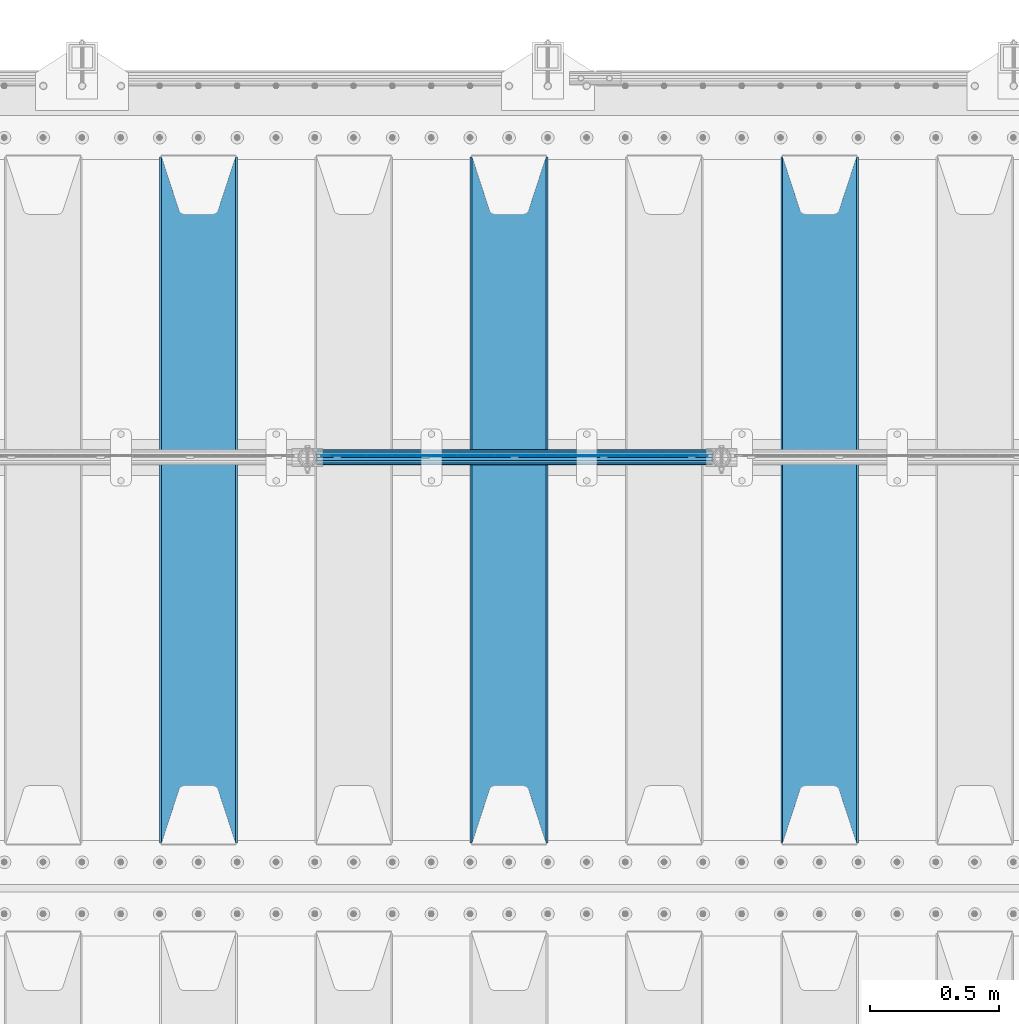
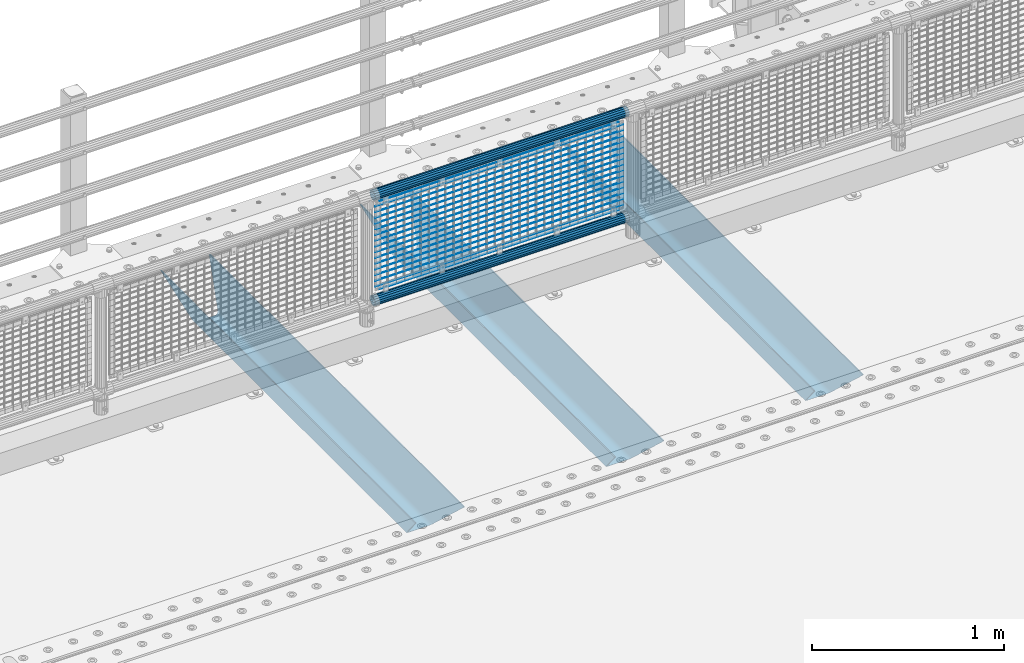
# One storey, part 123 of 257: 22 beams.
"""IFC2X3 building model written with IfcOpenShell, lengths in millimetres."""

import ifcopenshell
import ifcopenshell.guid

model = None  # the IFC model being written
_history = None  # IfcOwnerHistory: only IFC2X3 demands one
_inside = {}  # id of a spatial element -> (the spatial element, [elements in it])
_under = {}  # id of a project, library or spatial element -> (it, [spatial elements below it])
_declared = {}  # id of a project -> (the project, [libraries it declares])
_typed = {}  # id of a type object -> (the type object, [elements of that type])
_made_of = {}  # id of a material, layer set ... -> (it, [elements and type objects made of it])


def new_model(schema):
    """Start an empty IFC model of exactly this schema.

    Asked for "IFC4X3", IfcOpenShell would pick the latest addendum, in which some entities
    have other attributes; the version numbers below select the first issue.
    IFC2X3 requires an IfcOwnerHistory on every rooted entity: one is made here for all.
    """
    global model, _history
    if schema == "IFC4X3":
        model = ifcopenshell.file(schema_version=(4, 3, 0, 0))
    else:
        model = ifcopenshell.file(schema=schema)
    _inside.clear()
    _under.clear()
    _declared.clear()
    _typed.clear()
    _made_of.clear()
    _history = None
    if model.schema == "IFC2X3":
        org = make("IfcOrganization", Name="unknown")
        user = make(
            "IfcPersonAndOrganization",
            ThePerson=make("IfcPerson", FamilyName="unknown"),
            TheOrganization=org,
        )
        app = make(
            "IfcApplication",
            ApplicationDeveloper=org,
            Version="unknown",
            ApplicationFullName="unknown",
            ApplicationIdentifier="unknown",
        )
        _history = make(
            "IfcOwnerHistory",
            OwningUser=user,
            OwningApplication=app,
            ChangeAction="ADDED",
            CreationDate=0,
        )
    return model


def make(cls, **values):
    """One entity of the class cls with the attributes given. An attribute that is None is left unset."""
    return model.create_entity(
        cls, **{name: value for name, value in values.items() if value is not None}
    )


def rooted(cls, **values):
    """An entity with a GlobalId (a new one), such as an element, a storey or a relation."""
    return make(cls, GlobalId=ifcopenshell.guid.new(), OwnerHistory=_history, **values)


def si_unit(unit_type, name, prefix=None):
    """IfcSIUnit, for example si_unit("LENGTHUNIT", "METRE", prefix="MILLI")."""
    return make("IfcSIUnit", UnitType=unit_type, Prefix=prefix, Name=name)


def assignment(units):
    """IfcUnitAssignment: the units of a project."""
    return None if units is None else make("IfcUnitAssignment", Units=units)


def point(xyz):
    """IfcCartesianPoint."""
    return None if xyz is None else make("IfcCartesianPoint", Coordinates=xyz)


def direction(xyz):
    """IfcDirection."""
    return None if xyz is None else make("IfcDirection", DirectionRatios=xyz)


def frame(location, z_axis=None, x_axis=None):
    """IfcAxis2Placement3D, a coordinate frame: its origin and axes. An axis left out is left unset."""
    return make(
        "IfcAxis2Placement3D",
        Location=point(location),
        Axis=direction(z_axis),
        RefDirection=direction(x_axis),
    )


def origin_with_axes():
    """The frame at (0, 0, 0) with the z axis (0, 0, 1) and the x axis (1, 0, 0) written out."""
    return frame((0.0, 0.0, 0.0), z_axis=(0.0, 0.0, 1.0), x_axis=(1.0, 0.0, 0.0))


def place(relative_to, where):
    """IfcLocalPlacement: puts the frame where relative to a parent placement (None: the world)."""
    return make(
        "IfcLocalPlacement", PlacementRelTo=relative_to, RelativePlacement=where
    )


def context(
    kind, dimensions, precision=None, world=None, true_north=None, identifier=None
):
    """IfcGeometricRepresentationContext, for example the 3D "Model" context."""
    return make(
        "IfcGeometricRepresentationContext",
        ContextIdentifier=identifier,
        ContextType=kind,
        CoordinateSpaceDimension=dimensions,
        Precision=precision,
        WorldCoordinateSystem=world,
        TrueNorth=true_north,
    )


def subcontext(parent, identifier, kind, view, scale=None):
    """IfcGeometricRepresentationSubContext, for example "Body" below "Model"."""
    return make(
        "IfcGeometricRepresentationSubContext",
        ContextIdentifier=identifier,
        ContextType=kind,
        ParentContext=parent,
        TargetScale=scale,
        TargetView=view,
    )


def project(units=None, contexts=None):
    """IfcProject with its units and contexts."""
    return rooted(
        "IfcProject",
        Name="project",
        RepresentationContexts=contexts,
        UnitsInContext=assignment(units),
    )


def spatial(cls, under=None, at=None, **own):
    """A site, building, storey or space (cls), placed at a placement, below another one or the project."""
    s = rooted(cls, ObjectPlacement=at, **own)
    if under is not None:
        _under.setdefault(under.id(), (under, []))[1].append(s)
    return s


def faces_of(points, faces, orient=None, outer=None):
    """IfcFace entities. A face is a list of loops; a loop is a list of indices into points, from 0.

    orient and outer hold one flag for each loop. By default every Orientation is true, the
    first loop of a face is its IfcFaceOuterBound and the others are IfcFaceBound.
    """
    made = []
    for i, loops in enumerate(faces):
        bounds = []
        for j, loop in enumerate(loops):
            is_outer = j == 0 if outer is None else outer[i][j]
            bounds.append(
                make(
                    "IfcFaceOuterBound" if is_outer else "IfcFaceBound",
                    Bound=make("IfcPolyLoop", Polygon=[points[k] for k in loop]),
                    Orientation=True if orient is None else orient[i][j],
                )
            )
        made.append(make("IfcFace", Bounds=bounds))
    return made


def faceted_brep(points, faces, orient=None, outer=None, voids=None):
    """IfcFacetedBrep: a solid bounded by flat faces; with voids (closed shells), ...WithVoids."""
    shared = [point(p) for p in points]
    hull = make("IfcClosedShell", CfsFaces=faces_of(shared, faces, orient, outer))
    if voids is None:
        return make("IfcFacetedBrep", Outer=hull)
    return make(
        "IfcFacetedBrepWithVoids",
        Outer=hull,
        Voids=[
            make(cls, CfsFaces=faces_of(shared, fs, o, b)) for cls, fs, o, b in voids
        ],
    )


def shape(context_of_items, identifier, shape_type, items):
    """IfcShapeRepresentation: the items that make up one representation, for example the "Body"."""
    return make(
        "IfcShapeRepresentation",
        ContextOfItems=context_of_items,
        RepresentationIdentifier=identifier,
        RepresentationType=shape_type,
        Items=items,
    )


def material(Name=None, Category=None):
    """IfcMaterial."""
    return make("IfcMaterial", Name=Name, Category=Category)


def made_of(thing, what):
    """Note that an element or type object is made of a material, layer set ...; save() writes the relation."""
    if what is not None:
        _made_of.setdefault(what.id(), (what, []))[1].append(thing)
    return thing


def type_object(cls, material=None, **own):
    """A type object (cls), such as IfcWallType, which elements share."""
    return made_of(rooted(cls, **own), material)


def element(
    cls,
    number,
    at=None,
    inside=None,
    cuts=None,
    type_object=None,
    material=None,
    context=None,
    identifier="Body",
    shape_type=None,
    held_by="IfcProductDefinitionShape",
    body=None,
    shapes=None,
    **own,
):
    """One element of the class cls, such as IfcWall. Its Tag is "e" and its number.

    at: its placement. inside: the storey or other place that contains it. cuts: it is an
    opening in that element (IfcRelVoidsElement). A single representation is given by context,
    identifier, shape_type and body (its items); several are given by shapes. held_by: the class
    of the entity that holds the representations. save() writes the other relations.
    """
    e = rooted(cls, Tag="e%d" % number, ObjectPlacement=at, **own)
    if body is not None:
        shapes = [shape(context, identifier, shape_type, body)]
    if shapes is not None:
        e.Representation = make(held_by, Representations=shapes)
    if inside is not None:
        _inside.setdefault(inside.id(), (inside, []))[1].append(e)
    if cuts is not None:
        rooted(
            "IfcRelVoidsElement", RelatingBuildingElement=cuts, RelatedOpeningElement=e
        )
    if type_object is not None:
        _typed.setdefault(type_object.id(), (type_object, []))[1].append(e)
    return made_of(e, material)


def aggregate(whole, parts):
    """IfcRelAggregates: a whole, such as a stair, and the parts it consists of."""
    return rooted("IfcRelAggregates", RelatingObject=whole, RelatedObjects=parts)


def save(model, path):
    """Write the relations noted so far, then the file.

    IfcRelAggregates (storeys below a building ...), IfcRelContainedInSpatialStructure (elements
    in a storey), IfcRelDefinesByType, IfcRelAssociatesMaterial and IfcRelDeclares: one each for
    every whole, place, type object, material and project.
    """
    for whole, parts in _under.values():
        aggregate(whole, parts)
    for where, things in _inside.values():
        rooted(
            "IfcRelContainedInSpatialStructure",
            RelatedElements=things,
            RelatingStructure=where,
        )
    for kind, things in _typed.values():
        rooted("IfcRelDefinesByType", RelatedObjects=things, RelatingType=kind)
    for what, things in _made_of.values():
        rooted("IfcRelAssociatesMaterial", RelatedObjects=things, RelatingMaterial=what)
    for by, libraries in _declared.values():
        rooted("IfcRelDeclares", RelatingContext=by, RelatedDefinitions=libraries)
    model.write(path)


model = new_model("IFC2X3")

# Units and contexts
model_context = context("Model", 3, precision=1e-05, world=origin_with_axes())
body_context = subcontext(model_context, "Body", "Model", "MODEL_VIEW")
ifc_project = project(units=[si_unit("LENGTHUNIT", "METRE", prefix="MILLI"), si_unit("AREAUNIT", "SQUARE_METRE"), si_unit("VOLUMEUNIT", "CUBIC_METRE"), si_unit("MASSUNIT", "GRAM", prefix="KILO"), si_unit("TIMEUNIT", "SECOND"), si_unit("PLANEANGLEUNIT", "RADIAN"), si_unit("SOLIDANGLEUNIT", "STERADIAN"), si_unit("THERMODYNAMICTEMPERATUREUNIT", "DEGREE_CELSIUS"), si_unit("LUMINOUSINTENSITYUNIT", "LUMEN")], contexts=[model_context])

# Site, building, storey
site_placement = place(None, origin_with_axes())
site = spatial("IfcSite", under=ifc_project, at=site_placement, CompositionType="ELEMENT")
building_placement = place(site_placement, origin_with_axes())
building = spatial("IfcBuilding", under=site, at=building_placement, Name="Standard", CompositionType="ELEMENT")
storey_placement = place(building_placement, origin_with_axes())
storey = spatial("IfcBuildingStorey", under=building, at=storey_placement, Name="Undefined", CompositionType="ELEMENT", Elevation=0.0)

# Beams
ifc_material_1 = material(Name="STEEL/S355N")
beam_type_1 = type_object("IfcBeamType", PredefinedType="NOTDEFINED")
beam_1_placement = place(storey_placement, frame((53050.0, 9175.0, -115.0), z_axis=(0.0, 0.0, 1.0), x_axis=(0.0, 1.0, 0.0)))
element("IfcBeam", 1, at=beam_1_placement, inside=storey, type_object=beam_type_1, material=ifc_material_1, context=body_context, shape_type="Brep", body=[
    faceted_brep([(0.0, 150.0, 115.0), (0.0, 143.690000000002, 115.0), (2650.00000000297, 143.690000000002, 115.0), (2650.00000000297, 150.0, 115.0), (2650.00000000297, 142.059565218406, 110.0000000031), (2650.00000000297, 148.369565218403, 110.0000000031), (2441.90079219208, -80.1103600731149, -98.0992078077845), (2437.7588105432, -77.5672621345584, -102.241189456673), (2434.06523489746, -74.4080125315522, -105.934765102404), (2430.91086095089, -70.7102721255724, -109.089139048974), (2428.37322971128, -66.5649389910031, -111.626770288588), (2426.51472138055, -62.0739139532889, -113.485278619323), (2425.38102192091, -57.3475956567636, -114.618978078955), (2424.99999999987, -52.5021667386536, -115.0), (2424.99999999987, 52.5021667386536, -115.0), (2425.38102192091, 57.3475956567636, -114.618978078955), (2426.51472138055, 62.0739139532889, -113.485278619323), (2428.37322971128, 66.5649389910031, -111.626770288588), (2430.91086095089, 70.7102721255724, -109.089139048974), (2434.06523489746, 74.4080125315522, -105.934765102404), (2437.7588105432, 77.5672621345584, -102.241189456673), (2441.90079219208, 80.1103600731149, -98.0992078077846), (2446.38936140511, 81.9747917625791, -93.6106385947584), (2448.24948500409, 76.2713538057287, -91.7505149957729), (2444.62967112262, 74.76777986261, -95.3703288772456), (2441.28936334126, 72.7168944282894, -98.710636658607), (2438.31067330438, 70.1691124903809, -101.689326695487), (2435.76682334747, 67.1870637758839, -104.233176652398), (2433.72034654133, 63.8440531834931, -106.279653458539), (2432.22154950041, 60.2222587982324, -107.778450499454), (2431.30727574265, 56.4107117849126, -108.692724257221), (2430.99999999987, 52.5031078186876, -109.0), (2430.99999999987, -52.5031078186876, -109.0), (2431.30727574265, -56.4107117849126, -108.692724257221), (2432.22154950041, -60.2222587982324, -107.778450499454), (2433.72034654133, -63.8440531834931, -106.279653458539), (2435.76682334747, -67.1870637758839, -104.233176652398), (2438.31067330438, -70.1691124903809, -101.689326695487), (2441.28936334126, -72.7168944282894, -98.7106366586071), (2444.62967112262, -74.76777986261, -95.3703288772457), (2448.24948500409, -76.2713538057287, -91.7505149957729), (2650.00000000297, -142.059565218406, 110.0000000031), (2650.00000000297, -148.369565218403, 110.0000000031), (2446.38936140511, -81.9747917625791, -93.6106385947584), (2650.00000000297, -143.690000000002, 115.0), (2650.00000000297, -150.0, 115.0), (0.0, -143.690000000002, 115.0), (0.0, -150.0, 115.0), (0.0, -148.369565218258, 110.000000002662), (203.61063859742, -81.9747917625791, -93.6106385947584), (208.099207810447, -80.1103600731149, -98.0992078077845), (212.241189459335, -77.5672621345584, -102.241189456673), (215.934765105066, -74.4080125315522, -105.934765102404), (219.089139051636, -70.7102721255724, -109.089139048974), (221.626770291251, -66.5649389910031, -111.626770288588), (223.485278621985, -62.0739139532889, -113.485278619323), (224.618978081617, -57.3475956567636, -114.618978078955), (225.000000002662, -52.5021667386536, -115.0), (225.000000002662, 52.5021667386536, -115.0), (224.618978081617, 57.3475956567636, -114.618978078955), (223.485278621985, 62.0739139532889, -113.485278619323), (221.626770291251, 66.5649389910031, -111.626770288588), (219.089139051636, 70.7102721255724, -109.089139048974), (215.934765105066, 74.4080125315522, -105.934765102404), (212.241189459335, 77.5672621345584, -102.241189456673), (208.099207810447, 80.1103600731149, -98.0992078077846), (203.61063859742, 81.9747917625791, -93.6106385947584), (0.0, 148.369565218258, 110.000000002662), (0.0, 142.05956521826, 110.000000002662), (201.750514998435, 76.2713538057287, -91.7505149957729), (205.370328879908, 74.76777986261, -95.3703288772456), (208.710636661269, 72.7168944282894, -98.710636658607), (211.689326698149, 70.1691124903809, -101.689326695487), (214.233176655061, 67.1870637758839, -104.233176652398), (216.279653461201, 63.8440531834931, -106.279653458539), (217.778450502116, 60.2222587982324, -107.778450499454), (218.692724259884, 56.4107117849126, -108.692724257221), (219.000000002662, 52.5031078186876, -109.0), (219.000000002662, -52.5031078186876, -109.0), (218.692724259884, -56.4107117849126, -108.692724257221), (217.778450502116, -60.2222587982324, -107.778450499454), (216.279653461201, -63.8440531834931, -106.279653458539), (214.233176655061, -67.1870637758839, -104.233176652398), (211.689326698149, -70.1691124903809, -101.689326695487), (208.710636661269, -72.7168944282894, -98.7106366586071), (205.370328879908, -74.76777986261, -95.3703288772457), (201.750514998435, -76.2713538057287, -91.7505149957729), (0.0, -142.05956521826, 110.000000002662)], [[[0, 1, 2, 3]], [[3, 2, 4, 5]], [[6, 7, 8, 9, 10, 11, 12, 13, 14, 15, 16, 17, 18, 19, 20, 21, 22, 5, 4, 23, 24, 25, 26, 27, 28, 29, 30, 31, 32, 33, 34, 35, 36, 37, 38, 39, 40, 41, 42, 43]], [[44, 45, 42, 41]], [[46, 47, 45, 44]], [[43, 42, 45, 47, 48, 49]], [[6, 43, 49, 50]], [[7, 6, 50, 51]], [[8, 7, 51, 52]], [[9, 8, 52, 53]], [[10, 9, 53, 54]], [[11, 10, 54, 55]], [[12, 11, 55, 56]], [[13, 12, 56, 57]], [[14, 13, 57, 58]], [[15, 14, 58, 59]], [[16, 15, 59, 60]], [[17, 16, 60, 61]], [[18, 17, 61, 62]], [[19, 18, 62, 63]], [[20, 19, 63, 64]], [[21, 20, 64, 65]], [[22, 21, 65, 66]], [[0, 3, 5, 22, 66, 67]], [[1, 0, 67, 68]], [[23, 4, 2, 1, 68, 69]], [[24, 23, 69, 70]], [[25, 24, 70, 71]], [[26, 25, 71, 72]], [[27, 26, 72, 73]], [[28, 27, 73, 74]], [[29, 28, 74, 75]], [[30, 29, 75, 76]], [[31, 30, 76, 77]], [[32, 31, 77, 78]], [[33, 32, 78, 79]], [[34, 33, 79, 80]], [[35, 34, 80, 81]], [[36, 35, 81, 82]], [[37, 36, 82, 83]], [[38, 37, 83, 84]], [[39, 38, 84, 85]], [[40, 39, 85, 86]], [[46, 44, 41, 40, 86, 87]], [[47, 46, 87, 48]], [[86, 85, 84, 83, 82, 81, 80, 79, 78, 77, 76, 75, 74, 73, 72, 71, 70, 69, 68, 67, 66, 65, 64, 63, 62, 61, 60, 59, 58, 57, 56, 55, 54, 53, 52, 51, 50, 49, 48, 87]]]),
])
beam_2_placement = place(storey_placement, frame((51850.0, 9175.0, -115.0), z_axis=(0.0, 0.0, 1.0), x_axis=(0.0, 1.0, 0.0)))
element("IfcBeam", 2, at=beam_2_placement, inside=storey, type_object=beam_type_1, material=ifc_material_1, context=body_context, shape_type="Brep", body=[
    faceted_brep([(0.0, 150.0, 115.0), (0.0, 143.690000000002, 115.0), (2650.00000000297, 143.690000000002, 115.0), (2650.00000000297, 150.0, 115.0), (2650.00000000297, 142.059565218406, 110.0000000031), (2650.00000000297, 148.369565218403, 110.0000000031), (2441.90079219208, -80.1103600731149, -98.0992078077845), (2437.7588105432, -77.5672621345584, -102.241189456673), (2434.06523489746, -74.4080125315522, -105.934765102404), (2430.91086095089, -70.7102721255724, -109.089139048974), (2428.37322971128, -66.5649389910031, -111.626770288588), (2426.51472138055, -62.0739139532889, -113.485278619323), (2425.38102192091, -57.3475956567636, -114.618978078955), (2424.99999999987, -52.5021667386536, -115.0), (2424.99999999987, 52.5021667386536, -115.0), (2425.38102192091, 57.3475956567636, -114.618978078955), (2426.51472138055, 62.0739139532889, -113.485278619323), (2428.37322971128, 66.5649389910031, -111.626770288588), (2430.91086095089, 70.7102721255724, -109.089139048974), (2434.06523489746, 74.4080125315522, -105.934765102404), (2437.7588105432, 77.5672621345584, -102.241189456673), (2441.90079219208, 80.1103600731149, -98.0992078077846), (2446.38936140511, 81.9747917625791, -93.6106385947584), (2448.24948500409, 76.2713538057287, -91.7505149957729), (2444.62967112262, 74.76777986261, -95.3703288772456), (2441.28936334126, 72.7168944282894, -98.710636658607), (2438.31067330438, 70.1691124903809, -101.689326695487), (2435.76682334747, 67.1870637758839, -104.233176652398), (2433.72034654133, 63.8440531834931, -106.279653458539), (2432.22154950041, 60.2222587982324, -107.778450499454), (2431.30727574265, 56.4107117849126, -108.692724257221), (2430.99999999987, 52.5031078186876, -109.0), (2430.99999999987, -52.5031078186876, -109.0), (2431.30727574265, -56.4107117849126, -108.692724257221), (2432.22154950041, -60.2222587982324, -107.778450499454), (2433.72034654133, -63.8440531834931, -106.279653458539), (2435.76682334747, -67.1870637758839, -104.233176652398), (2438.31067330438, -70.1691124903809, -101.689326695487), (2441.28936334126, -72.7168944282894, -98.7106366586071), (2444.62967112262, -74.76777986261, -95.3703288772457), (2448.24948500409, -76.2713538057287, -91.7505149957729), (2650.00000000297, -142.059565218406, 110.0000000031), (2650.00000000297, -148.369565218403, 110.0000000031), (2446.38936140511, -81.9747917625791, -93.6106385947584), (2650.00000000297, -143.690000000002, 115.0), (2650.00000000297, -150.0, 115.0), (0.0, -143.690000000002, 115.0), (0.0, -150.0, 115.0), (0.0, -148.369565218258, 110.000000002662), (203.61063859742, -81.9747917625791, -93.6106385947584), (208.099207810447, -80.1103600731149, -98.0992078077845), (212.241189459335, -77.5672621345584, -102.241189456673), (215.934765105066, -74.4080125315522, -105.934765102404), (219.089139051636, -70.7102721255724, -109.089139048974), (221.626770291251, -66.5649389910031, -111.626770288588), (223.485278621985, -62.0739139532889, -113.485278619323), (224.618978081617, -57.3475956567636, -114.618978078955), (225.000000002662, -52.5021667386536, -115.0), (225.000000002662, 52.5021667386536, -115.0), (224.618978081617, 57.3475956567636, -114.618978078955), (223.485278621985, 62.0739139532889, -113.485278619323), (221.626770291251, 66.5649389910031, -111.626770288588), (219.089139051636, 70.7102721255724, -109.089139048974), (215.934765105066, 74.4080125315522, -105.934765102404), (212.241189459335, 77.5672621345584, -102.241189456673), (208.099207810447, 80.1103600731149, -98.0992078077846), (203.61063859742, 81.9747917625791, -93.6106385947584), (0.0, 148.369565218258, 110.000000002662), (0.0, 142.05956521826, 110.000000002662), (201.750514998435, 76.2713538057287, -91.7505149957729), (205.370328879908, 74.76777986261, -95.3703288772456), (208.710636661269, 72.7168944282894, -98.710636658607), (211.689326698149, 70.1691124903809, -101.689326695487), (214.233176655061, 67.1870637758839, -104.233176652398), (216.279653461201, 63.8440531834931, -106.279653458539), (217.778450502116, 60.2222587982324, -107.778450499454), (218.692724259884, 56.4107117849126, -108.692724257221), (219.000000002662, 52.5031078186876, -109.0), (219.000000002662, -52.5031078186876, -109.0), (218.692724259884, -56.4107117849126, -108.692724257221), (217.778450502116, -60.2222587982324, -107.778450499454), (216.279653461201, -63.8440531834931, -106.279653458539), (214.233176655061, -67.1870637758839, -104.233176652398), (211.689326698149, -70.1691124903809, -101.689326695487), (208.710636661269, -72.7168944282894, -98.7106366586071), (205.370328879908, -74.76777986261, -95.3703288772457), (201.750514998435, -76.2713538057287, -91.7505149957729), (0.0, -142.05956521826, 110.000000002662)], [[[0, 1, 2, 3]], [[3, 2, 4, 5]], [[6, 7, 8, 9, 10, 11, 12, 13, 14, 15, 16, 17, 18, 19, 20, 21, 22, 5, 4, 23, 24, 25, 26, 27, 28, 29, 30, 31, 32, 33, 34, 35, 36, 37, 38, 39, 40, 41, 42, 43]], [[44, 45, 42, 41]], [[46, 47, 45, 44]], [[43, 42, 45, 47, 48, 49]], [[6, 43, 49, 50]], [[7, 6, 50, 51]], [[8, 7, 51, 52]], [[9, 8, 52, 53]], [[10, 9, 53, 54]], [[11, 10, 54, 55]], [[12, 11, 55, 56]], [[13, 12, 56, 57]], [[14, 13, 57, 58]], [[15, 14, 58, 59]], [[16, 15, 59, 60]], [[17, 16, 60, 61]], [[18, 17, 61, 62]], [[19, 18, 62, 63]], [[20, 19, 63, 64]], [[21, 20, 64, 65]], [[22, 21, 65, 66]], [[0, 3, 5, 22, 66, 67]], [[1, 0, 67, 68]], [[23, 4, 2, 1, 68, 69]], [[24, 23, 69, 70]], [[25, 24, 70, 71]], [[26, 25, 71, 72]], [[27, 26, 72, 73]], [[28, 27, 73, 74]], [[29, 28, 74, 75]], [[30, 29, 75, 76]], [[31, 30, 76, 77]], [[32, 31, 77, 78]], [[33, 32, 78, 79]], [[34, 33, 79, 80]], [[35, 34, 80, 81]], [[36, 35, 81, 82]], [[37, 36, 82, 83]], [[38, 37, 83, 84]], [[39, 38, 84, 85]], [[40, 39, 85, 86]], [[46, 44, 41, 40, 86, 87]], [[47, 46, 87, 48]], [[86, 85, 84, 83, 82, 81, 80, 79, 78, 77, 76, 75, 74, 73, 72, 71, 70, 69, 68, 67, 66, 65, 64, 63, 62, 61, 60, 59, 58, 57, 56, 55, 54, 53, 52, 51, 50, 49, 48, 87]]]),
])
beam_3_placement = place(storey_placement, frame((50650.0, 9175.0, -115.0), z_axis=(0.0, 0.0, 1.0), x_axis=(0.0, 1.0, 0.0)))
element("IfcBeam", 3, at=beam_3_placement, inside=storey, type_object=beam_type_1, material=ifc_material_1, context=body_context, shape_type="Brep", body=[
    faceted_brep([(0.0, 150.0, 115.0), (0.0, 143.690000000002, 115.0), (2650.00000000297, 143.690000000002, 115.0), (2650.00000000297, 150.0, 115.0), (2650.00000000297, 142.059565218406, 110.0000000031), (2650.00000000297, 148.369565218403, 110.0000000031), (2441.90079219208, -80.1103600731149, -98.0992078077845), (2437.7588105432, -77.5672621345584, -102.241189456673), (2434.06523489746, -74.4080125315522, -105.934765102404), (2430.91086095089, -70.7102721255724, -109.089139048974), (2428.37322971128, -66.5649389910031, -111.626770288588), (2426.51472138055, -62.0739139532889, -113.485278619323), (2425.38102192091, -57.3475956567636, -114.618978078955), (2424.99999999987, -52.5021667386536, -115.0), (2424.99999999987, 52.5021667386536, -115.0), (2425.38102192091, 57.3475956567636, -114.618978078955), (2426.51472138055, 62.0739139532889, -113.485278619323), (2428.37322971128, 66.5649389910031, -111.626770288588), (2430.91086095089, 70.7102721255724, -109.089139048974), (2434.06523489746, 74.4080125315522, -105.934765102404), (2437.7588105432, 77.5672621345584, -102.241189456673), (2441.90079219208, 80.1103600731149, -98.0992078077846), (2446.38936140511, 81.9747917625791, -93.6106385947584), (2448.24948500409, 76.2713538057287, -91.7505149957729), (2444.62967112262, 74.76777986261, -95.3703288772456), (2441.28936334126, 72.7168944282894, -98.710636658607), (2438.31067330438, 70.1691124903809, -101.689326695487), (2435.76682334747, 67.1870637758839, -104.233176652398), (2433.72034654133, 63.8440531834931, -106.279653458539), (2432.22154950041, 60.2222587982324, -107.778450499454), (2431.30727574265, 56.4107117849126, -108.692724257221), (2430.99999999987, 52.5031078186876, -109.0), (2430.99999999987, -52.5031078186876, -109.0), (2431.30727574265, -56.4107117849126, -108.692724257221), (2432.22154950041, -60.2222587982324, -107.778450499454), (2433.72034654133, -63.8440531834931, -106.279653458539), (2435.76682334747, -67.1870637758839, -104.233176652398), (2438.31067330438, -70.1691124903809, -101.689326695487), (2441.28936334126, -72.7168944282894, -98.7106366586071), (2444.62967112262, -74.76777986261, -95.3703288772457), (2448.24948500409, -76.2713538057287, -91.7505149957729), (2650.00000000297, -142.059565218406, 110.0000000031), (2650.00000000297, -148.369565218403, 110.0000000031), (2446.38936140511, -81.9747917625791, -93.6106385947584), (2650.00000000297, -143.690000000002, 115.0), (2650.00000000297, -150.0, 115.0), (0.0, -143.690000000002, 115.0), (0.0, -150.0, 115.0), (0.0, -148.369565218258, 110.000000002662), (203.61063859742, -81.9747917625791, -93.6106385947584), (208.099207810447, -80.1103600731149, -98.0992078077845), (212.241189459335, -77.5672621345584, -102.241189456673), (215.934765105066, -74.4080125315522, -105.934765102404), (219.089139051636, -70.7102721255724, -109.089139048974), (221.626770291251, -66.5649389910031, -111.626770288588), (223.485278621985, -62.0739139532889, -113.485278619323), (224.618978081617, -57.3475956567636, -114.618978078955), (225.000000002662, -52.5021667386536, -115.0), (225.000000002662, 52.5021667386536, -115.0), (224.618978081617, 57.3475956567636, -114.618978078955), (223.485278621985, 62.0739139532889, -113.485278619323), (221.626770291251, 66.5649389910031, -111.626770288588), (219.089139051636, 70.7102721255724, -109.089139048974), (215.934765105066, 74.4080125315522, -105.934765102404), (212.241189459335, 77.5672621345584, -102.241189456673), (208.099207810447, 80.1103600731149, -98.0992078077846), (203.61063859742, 81.9747917625791, -93.6106385947584), (0.0, 148.369565218258, 110.000000002662), (0.0, 142.05956521826, 110.000000002662), (201.750514998435, 76.2713538057287, -91.7505149957729), (205.370328879908, 74.76777986261, -95.3703288772456), (208.710636661269, 72.7168944282894, -98.710636658607), (211.689326698149, 70.1691124903809, -101.689326695487), (214.233176655061, 67.1870637758839, -104.233176652398), (216.279653461201, 63.8440531834931, -106.279653458539), (217.778450502116, 60.2222587982324, -107.778450499454), (218.692724259884, 56.4107117849126, -108.692724257221), (219.000000002662, 52.5031078186876, -109.0), (219.000000002662, -52.5031078186876, -109.0), (218.692724259884, -56.4107117849126, -108.692724257221), (217.778450502116, -60.2222587982324, -107.778450499454), (216.279653461201, -63.8440531834931, -106.279653458539), (214.233176655061, -67.1870637758839, -104.233176652398), (211.689326698149, -70.1691124903809, -101.689326695487), (208.710636661269, -72.7168944282894, -98.7106366586071), (205.370328879908, -74.76777986261, -95.3703288772457), (201.750514998435, -76.2713538057287, -91.7505149957729), (0.0, -142.05956521826, 110.000000002662)], [[[0, 1, 2, 3]], [[3, 2, 4, 5]], [[6, 7, 8, 9, 10, 11, 12, 13, 14, 15, 16, 17, 18, 19, 20, 21, 22, 5, 4, 23, 24, 25, 26, 27, 28, 29, 30, 31, 32, 33, 34, 35, 36, 37, 38, 39, 40, 41, 42, 43]], [[44, 45, 42, 41]], [[46, 47, 45, 44]], [[43, 42, 45, 47, 48, 49]], [[6, 43, 49, 50]], [[7, 6, 50, 51]], [[8, 7, 51, 52]], [[9, 8, 52, 53]], [[10, 9, 53, 54]], [[11, 10, 54, 55]], [[12, 11, 55, 56]], [[13, 12, 56, 57]], [[14, 13, 57, 58]], [[15, 14, 58, 59]], [[16, 15, 59, 60]], [[17, 16, 60, 61]], [[18, 17, 61, 62]], [[19, 18, 62, 63]], [[20, 19, 63, 64]], [[21, 20, 64, 65]], [[22, 21, 65, 66]], [[0, 3, 5, 22, 66, 67]], [[1, 0, 67, 68]], [[23, 4, 2, 1, 68, 69]], [[24, 23, 69, 70]], [[25, 24, 70, 71]], [[26, 25, 71, 72]], [[27, 26, 72, 73]], [[28, 27, 73, 74]], [[29, 28, 74, 75]], [[30, 29, 75, 76]], [[31, 30, 76, 77]], [[32, 31, 77, 78]], [[33, 32, 78, 79]], [[34, 33, 79, 80]], [[35, 34, 80, 81]], [[36, 35, 81, 82]], [[37, 36, 82, 83]], [[38, 37, 83, 84]], [[39, 38, 84, 85]], [[40, 39, 85, 86]], [[46, 44, 41, 40, 86, 87]], [[47, 46, 87, 48]], [[86, 85, 84, 83, 82, 81, 80, 79, 78, 77, 76, 75, 74, 73, 72, 71, 70, 69, 68, 67, 66, 65, 64, 63, 62, 61, 60, 59, 58, 57, 56, 55, 54, 53, 52, 51, 50, 49, 48, 87]]]),
])
ifc_material_2 = material(Name="Misc_Undefined")
beam_type_2 = type_object("IfcBeamType", Name="D3", PredefinedType="NOTDEFINED")
for number, where, z_axis, x_axis in (
    (4, (51126.0, 10670.5, 851.597000000003), (0.0, 0.0, 1.0), (1.0, 0.0, 0.0)),
    (5, (51126.0, 10670.5, 669.452000000003), (0.0, 0.0, 1.0), (1.0, 0.0, 0.0)),
    (6, (51126.0, 10670.5, 523.736000000003), (0.0, 0.0, 1.0), (1.0, 0.0, 0.0)),
    (7, (51126.0, 10670.5, 487.307000000003), (0.0, 0.0, 1.0), (1.0, 0.0, 0.0)),
    (8, (51126.0, 10670.5, 705.881000000003), (0.0, 0.0, 1.0), (1.0, 0.0, 0.0)),
    (9, (51126.0, 10670.5, 596.594000000003), (0.0, 0.0, 1.0), (1.0, 0.0, 0.0)),
    (10, (51126.0, 10670.5, 450.878000000003), (0.0, 0.0, 1.0), (1.0, 0.0, 0.0)),
    (11, (51126.0, 10670.5, 815.168000000003), (0.0, 0.0, 1.0), (1.0, 0.0, 0.0)),
    (12, (51126.0, 10670.5, 888.026000000003), (0.0, 0.0, 1.0), (1.0, 0.0, 0.0)),
    (13, (51126.0, 10670.5, 778.739000000003), (0.0, 0.0, 1.0), (1.0, 0.0, 0.0)),
    (14, (51126.0, 10670.5, 742.310000000003), (0.0, 0.0, 1.0), (1.0, 0.0, 0.0)),
    (15, (51126.0, 10670.5, 633.023000000003), (0.0, 0.0, 1.0), (1.0, 0.0, 0.0)),
    (16, (51126.0, 10670.5, 560.165000000003), (0.0, 0.0, 1.0), (1.0, 0.0, 0.0)),
    (17, (51126.0, 10670.5, 414.449000000003), (0.0, 0.0, 1.0), (1.0, 0.0, 0.0)),
):
    element("IfcBeam", number, at=place(storey_placement, frame(where, z_axis=z_axis, x_axis=x_axis)), inside=storey, type_object=beam_type_2, material=ifc_material_2, ObjectType="D3", context=body_context, shape_type="Brep", body=[
        faceted_brep([(0.0, -1.5, -5.6843418860808e-14), (0.0, -0.750000000001819, -1.29903810567669), (1490.0, -0.75, -1.29903810567669), (1490.0, -1.5, 0.0), (7.27595761418343e-12, 0.749999999998181, -1.29903810567669), (1490.0, 0.75, -1.29903810567669), (0.0, 1.5, -5.6843418860808e-14), (1490.0, 1.5, 0.0), (7.27595761418343e-12, 0.749999999998181, 1.29903810567669), (1490.0, 0.75, 1.29903810567669), (0.0, -0.750000000001819, 1.29903810567669), (1490.0, -0.75, 1.29903810567669)], [[[0, 1, 2, 3]], [[1, 4, 5, 2]], [[4, 6, 7, 5]], [[6, 8, 9, 7]], [[8, 10, 11, 9]], [[10, 0, 3, 11]], [[5, 7, 9, 11, 3, 2]], [[10, 8, 6, 4, 1, 0]]]),
    ])
beam_4_placement = place(storey_placement, frame((51151.0, 10670.5, 353.020000000003), z_axis=(0.0, 0.0, 1.0), x_axis=(1.0, 0.0, 0.0)))
element("IfcBeam", 18, at=beam_4_placement, inside=storey, type_object=beam_type_2, material=ifc_material_2, ObjectType="D3", context=body_context, shape_type="Brep", body=[
    faceted_brep([(0.0, -1.5, -5.6843418860808e-14), (0.0, -0.750000000001819, -1.29903810567669), (1440.0, -0.75, -1.29903810567669), (1440.0, -1.5, 0.0), (7.27595761418343e-12, 0.749999999998181, -1.29903810567669), (1440.0, 0.75, -1.29903810567663), (0.0, 1.5, -5.6843418860808e-14), (1440.0, 1.5, 0.0), (7.27595761418343e-12, 0.749999999998181, 1.29903810567669), (1440.0, 0.75, 1.29903810567669), (0.0, -0.750000000001819, 1.29903810567669), (1440.0, -0.75, 1.29903810567669)], [[[0, 1, 2, 3]], [[1, 4, 5, 2]], [[4, 6, 7, 5]], [[6, 8, 9, 7]], [[8, 10, 11, 9]], [[10, 0, 3, 11]], [[5, 7, 9, 11, 3, 2]], [[10, 8, 6, 4, 1, 0]]]),
])
beam_5_placement = place(storey_placement, frame((51126.0, 10670.5, 378.020000000003), z_axis=(0.0, 0.0, 1.0), x_axis=(1.0, 0.0, 0.0)))
element("IfcBeam", 19, at=beam_5_placement, inside=storey, type_object=beam_type_2, material=ifc_material_2, ObjectType="D3", context=body_context, shape_type="Brep", body=[
    faceted_brep([(0.0, -1.5, -5.6843418860808e-14), (0.0, -0.750000000001819, -1.29903810567669), (1490.0, -0.75, -1.29903810567669), (1490.0, -1.5, 0.0), (7.27595761418343e-12, 0.749999999998181, -1.29903810567669), (1490.0, 0.75, -1.29903810567669), (0.0, 1.5, -5.6843418860808e-14), (1490.0, 1.5, 0.0), (7.27595761418343e-12, 0.749999999998181, 1.29903810567669), (1490.0, 0.75, 1.29903810567669), (0.0, -0.750000000001819, 1.29903810567669), (1490.0, -0.75, 1.29903810567669)], [[[0, 1, 2, 3]], [[1, 4, 5, 2]], [[4, 6, 7, 5]], [[6, 8, 9, 7]], [[8, 10, 11, 9]], [[10, 0, 3, 11]], [[5, 7, 9, 11, 3, 2]], [[10, 8, 6, 4, 1, 0]]]),
])
beam_6_placement = place(storey_placement, frame((51151.0, 10670.5, 913.020000000003), z_axis=(0.0, 0.0, 1.0), x_axis=(1.0, 0.0, 0.0)))
element("IfcBeam", 20, at=beam_6_placement, inside=storey, type_object=beam_type_2, material=ifc_material_2, ObjectType="D3", context=body_context, shape_type="Brep", body=[
    faceted_brep([(0.0, -1.5, -5.6843418860808e-14), (0.0, -0.750000000001819, -1.29903810567669), (1440.0, -0.75, -1.29903810567669), (1440.0, -1.5, 0.0), (7.27595761418343e-12, 0.749999999998181, -1.29903810567669), (1440.0, 0.75, -1.29903810567663), (0.0, 1.5, -5.6843418860808e-14), (1440.0, 1.5, 0.0), (7.27595761418343e-12, 0.749999999998181, 1.29903810567669), (1440.0, 0.75, 1.29903810567669), (0.0, -0.750000000001819, 1.29903810567669), (1440.0, -0.75, 1.29903810567669)], [[[0, 1, 2, 3]], [[1, 4, 5, 2]], [[4, 6, 7, 5]], [[6, 8, 9, 7]], [[8, 10, 11, 9]], [[10, 0, 3, 11]], [[5, 7, 9, 11, 3, 2]], [[10, 8, 6, 4, 1, 0]]]),
])
ifc_material_3 = material()
beam_type_3 = type_object("IfcBeamType", PredefinedType="NOTDEFINED")
beam_7_placement = place(storey_placement, frame((51105.85, 10664.5, 298.170000000004), z_axis=(0.0, 0.0, 1.0), x_axis=(1.0, 0.0, 0.0)))
element("IfcBeam", 21, at=beam_7_placement, inside=storey, type_object=beam_type_3, material=ifc_material_3, context=body_context, shape_type="Brep", body=[
    faceted_brep([(0.0, -25.3500000000004, 0.0), (0.0, -23.4203461491616, 9.70102501045767), (1530.0, -23.4203461491616, 9.70102501045506), (1530.0, -25.3500000000004, 0.0), (0.0, -17.9251569030785, 17.9251569030821), (1530.0, -17.9251569030785, 17.925156903079), (0.0, -9.70102501045585, 23.4203461491634), (1530.0, -9.70102501045585, 23.4203461491611), (0.0, 0.0, 25.3499999999985), (1530.0, 0.0, 25.35), (0.0, 9.70102501045585, 23.4203461491634), (1530.0, 9.70102501045585, 23.4203461491611), (0.0, 17.9251569030785, 17.9251569030821), (1530.0, 17.9251569030785, 17.925156903079), (0.0, 23.4203461491616, 9.70102501045767), (1530.0, 23.4203461491616, 9.701025010455), (0.0, 25.3500000000004, 0.0), (1530.0, 25.3500000000004, 0.0), (0.0, 23.4203461491616, -9.70102501045767), (1530.0, 23.4203461491616, -9.70102501045506), (0.0, 17.9251569030785, -17.9251569030821), (1530.0, 17.9251569030785, -17.925156903079), (0.0, 9.70102501045585, -23.4203461491634), (1530.0, 9.70102501045585, -23.4203461491611), (0.0, 0.0, -25.3499999999985), (1530.0, 0.0, -25.35), (0.0, -9.70102501045585, -23.4203461491634), (1530.0, -9.70102501045585, -23.4203461491611), (0.0, -17.9251569030785, -17.9251569030821), (1530.0, -17.9251569030785, -17.925156903079), (0.0, -23.4203461491616, -9.70102501045767), (1530.0, -23.4203461491616, -9.701025010455), (0.0, -30.1499999999996, 0.0), (0.0, -27.8549679052157, -11.5379054858058), (1530.0, -27.8549679052157, -11.5379054858075), (1530.0, -30.1499999999996, 0.0), (0.0, -21.3192694527752, -21.3192694527752), (1530.0, -21.3192694527752, -21.3192694527744), (0.0, -11.5379054858076, -27.8549679052157), (1530.0, -11.5379054858076, -27.8549679052153), (0.0, 0.0, -30.1500000000015), (1530.0, 0.0, -30.15), (0.0, 11.5379054858076, -27.8549679052157), (1530.0, 11.5379054858076, -27.8549679052153), (0.0, 21.3192694527752, -21.3192694527752), (1530.0, 21.3192694527752, -21.3192694527744), (0.0, 27.8549679052157, -11.5379054858058), (1530.0, 27.8549679052157, -11.5379054858075), (0.0, 30.1499999999996, 0.0), (1530.0, 30.1499999999996, 0.0), (0.0, 27.8549679052157, 11.5379054858058), (1530.0, 27.8549679052157, 11.5379054858075), (0.0, 21.3192694527752, 21.3192694527752), (1530.0, 21.3192694527752, 21.3192694527744), (0.0, 11.5379054858076, 27.8549679052157), (1530.0, 11.5379054858076, 27.8549679052153), (0.0, 0.0, 30.1500000000015), (1530.0, 0.0, 30.15), (0.0, -11.5379054858076, 27.8549679052157), (1530.0, -11.5379054858076, 27.8549679052153), (0.0, -21.3192694527752, 21.3192694527752), (1530.0, -21.3192694527752, 21.3192694527744), (0.0, -27.8549679052157, 11.5379054858058), (1530.0, -27.8549679052157, 11.5379054858075)], [[[0, 1, 2, 3]], [[1, 4, 5, 2]], [[4, 6, 7, 5]], [[6, 8, 9, 7]], [[8, 10, 11, 9]], [[10, 12, 13, 11]], [[12, 14, 15, 13]], [[14, 16, 17, 15]], [[16, 18, 19, 17]], [[18, 20, 21, 19]], [[20, 22, 23, 21]], [[22, 24, 25, 23]], [[24, 26, 27, 25]], [[26, 28, 29, 27]], [[28, 30, 31, 29]], [[30, 0, 3, 31]], [[32, 33, 34, 35]], [[33, 36, 37, 34]], [[36, 38, 39, 37]], [[38, 40, 41, 39]], [[40, 42, 43, 41]], [[42, 44, 45, 43]], [[44, 46, 47, 45]], [[46, 48, 49, 47]], [[48, 50, 51, 49]], [[50, 52, 53, 51]], [[52, 54, 55, 53]], [[54, 56, 57, 55]], [[56, 58, 59, 57]], [[58, 60, 61, 59]], [[60, 62, 63, 61]], [[62, 32, 35, 63]], [[37, 39, 41, 43, 45, 47, 49, 51, 53, 55, 57, 59, 61, 63, 35, 34], [5, 7, 9, 11, 13, 15, 17, 19, 21, 23, 25, 27, 29, 31, 3, 2]], [[62, 60, 58, 56, 54, 52, 50, 48, 46, 44, 42, 40, 38, 36, 33, 32], [30, 28, 26, 24, 22, 20, 18, 16, 14, 12, 10, 8, 6, 4, 1, 0]]]),
])
beam_8_placement = place(storey_placement, frame((51105.85, 10664.5, 969.850000000003), z_axis=(0.0, 0.0, 1.0), x_axis=(1.0, 0.0, 0.0)))
element("IfcBeam", 22, at=beam_8_placement, inside=storey, type_object=beam_type_3, material=ifc_material_3, context=body_context, shape_type="Brep", body=[
    faceted_brep([(0.0, -25.3500000000004, 0.0), (0.0, -23.4203461491616, 9.70102501045767), (1530.0, -23.4203461491616, 9.70102501045506), (1530.0, -25.3500000000004, 0.0), (0.0, -17.9251569030785, 17.9251569030821), (1530.0, -17.9251569030785, 17.925156903079), (0.0, -9.70102501045585, 23.4203461491634), (1530.0, -9.70102501045585, 23.4203461491611), (0.0, 0.0, 25.3499999999985), (1530.0, 0.0, 25.35), (0.0, 9.70102501045585, 23.4203461491634), (1530.0, 9.70102501045585, 23.4203461491611), (0.0, 17.9251569030785, 17.9251569030821), (1530.0, 17.9251569030785, 17.925156903079), (0.0, 23.4203461491616, 9.70102501045767), (1530.0, 23.4203461491616, 9.701025010455), (0.0, 25.3500000000004, 0.0), (1530.0, 25.3500000000004, 0.0), (0.0, 23.4203461491616, -9.70102501045767), (1530.0, 23.4203461491616, -9.70102501045506), (0.0, 17.9251569030785, -17.9251569030821), (1530.0, 17.9251569030785, -17.925156903079), (0.0, 9.70102501045585, -23.4203461491634), (1530.0, 9.70102501045585, -23.4203461491611), (0.0, 0.0, -25.3499999999985), (1530.0, 0.0, -25.35), (0.0, -9.70102501045585, -23.4203461491634), (1530.0, -9.70102501045585, -23.4203461491611), (0.0, -17.9251569030785, -17.9251569030821), (1530.0, -17.9251569030785, -17.925156903079), (0.0, -23.4203461491616, -9.70102501045767), (1530.0, -23.4203461491616, -9.701025010455), (0.0, -30.1499999999996, 0.0), (0.0, -27.8549679052157, -11.5379054858058), (1530.0, -27.8549679052157, -11.5379054858075), (1530.0, -30.1499999999996, 0.0), (0.0, -21.3192694527752, -21.3192694527752), (1530.0, -21.3192694527752, -21.3192694527744), (0.0, -11.5379054858076, -27.8549679052157), (1530.0, -11.5379054858076, -27.8549679052153), (0.0, 0.0, -30.1500000000015), (1530.0, 0.0, -30.15), (0.0, 11.5379054858076, -27.8549679052157), (1530.0, 11.5379054858076, -27.8549679052153), (0.0, 21.3192694527752, -21.3192694527752), (1530.0, 21.3192694527752, -21.3192694527744), (0.0, 27.8549679052157, -11.5379054858058), (1530.0, 27.8549679052157, -11.5379054858075), (0.0, 30.1499999999996, 0.0), (1530.0, 30.1499999999996, 0.0), (0.0, 27.8549679052157, 11.5379054858058), (1530.0, 27.8549679052157, 11.5379054858075), (0.0, 21.3192694527752, 21.3192694527752), (1530.0, 21.3192694527752, 21.3192694527744), (0.0, 11.5379054858076, 27.8549679052157), (1530.0, 11.5379054858076, 27.8549679052153), (0.0, 0.0, 30.1500000000015), (1530.0, 0.0, 30.15), (0.0, -11.5379054858076, 27.8549679052157), (1530.0, -11.5379054858076, 27.8549679052153), (0.0, -21.3192694527752, 21.3192694527752), (1530.0, -21.3192694527752, 21.3192694527744), (0.0, -27.8549679052157, 11.5379054858058), (1530.0, -27.8549679052157, 11.5379054858075)], [[[0, 1, 2, 3]], [[1, 4, 5, 2]], [[4, 6, 7, 5]], [[6, 8, 9, 7]], [[8, 10, 11, 9]], [[10, 12, 13, 11]], [[12, 14, 15, 13]], [[14, 16, 17, 15]], [[16, 18, 19, 17]], [[18, 20, 21, 19]], [[20, 22, 23, 21]], [[22, 24, 25, 23]], [[24, 26, 27, 25]], [[26, 28, 29, 27]], [[28, 30, 31, 29]], [[30, 0, 3, 31]], [[32, 33, 34, 35]], [[33, 36, 37, 34]], [[36, 38, 39, 37]], [[38, 40, 41, 39]], [[40, 42, 43, 41]], [[42, 44, 45, 43]], [[44, 46, 47, 45]], [[46, 48, 49, 47]], [[48, 50, 51, 49]], [[50, 52, 53, 51]], [[52, 54, 55, 53]], [[54, 56, 57, 55]], [[56, 58, 59, 57]], [[58, 60, 61, 59]], [[60, 62, 63, 61]], [[62, 32, 35, 63]], [[37, 39, 41, 43, 45, 47, 49, 51, 53, 55, 57, 59, 61, 63, 35, 34], [5, 7, 9, 11, 13, 15, 17, 19, 21, 23, 25, 27, 29, 31, 3, 2]], [[62, 60, 58, 56, 54, 52, 50, 48, 46, 44, 42, 40, 38, 36, 33, 32], [30, 28, 26, 24, 22, 20, 18, 16, 14, 12, 10, 8, 6, 4, 1, 0]]]),
])

save(model, "model.ifc")
